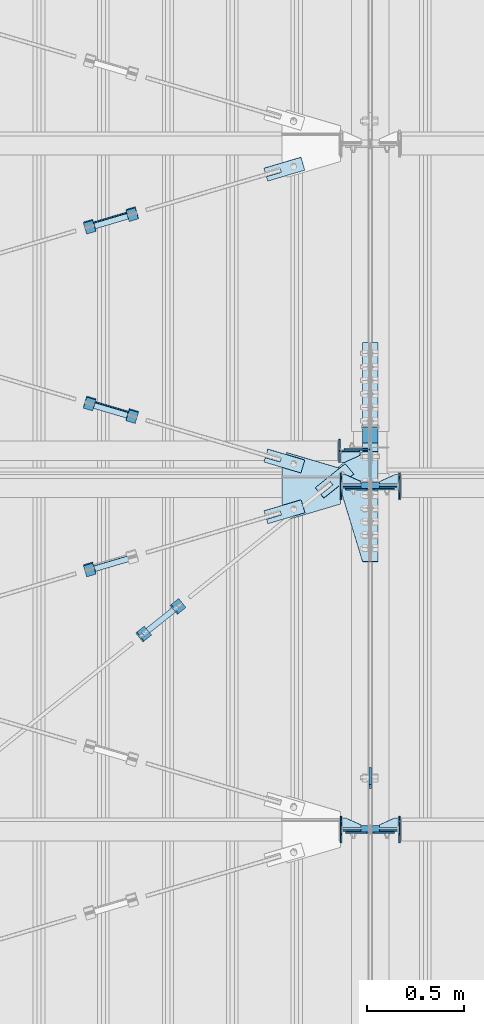
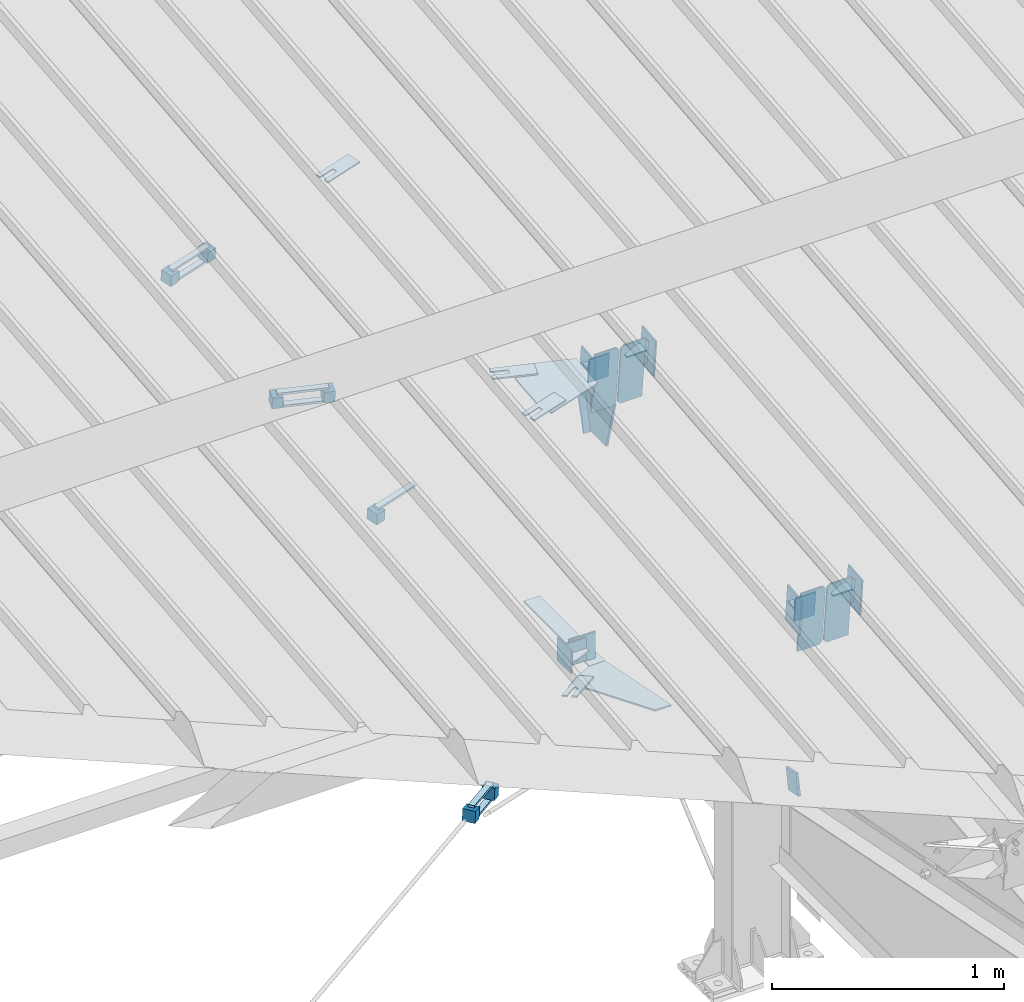
# One storey, part 149 of 709: 44 plates, 3 openings, 16 elements without a shape of their own.
"""IFC4 building model written with IfcOpenShell, lengths in millimetres."""

from ifc_helpers import new_model, si_unit, direction, frame, origin_with_axes, place, context, subcontext, project, spatial, line, indexed_curve, outline, extrude, material, element, aggregate, save


model = new_model("IFC4")

# Units and contexts
model_context = context("Model", 3, precision=0.2, world=origin_with_axes(), true_north=direction((0.0, 1.0)))
body_context = subcontext(model_context, "Body", "Model", "MODEL_VIEW")
ifc_project = project(units=[si_unit("LENGTHUNIT", "METRE", prefix="MILLI"), si_unit("AREAUNIT", "SQUARE_METRE"), si_unit("VOLUMEUNIT", "CUBIC_METRE"), si_unit("MASSUNIT", "GRAM", prefix="KILO"), si_unit("TIMEUNIT", "SECOND"), si_unit("PLANEANGLEUNIT", "RADIAN"), si_unit("SOLIDANGLEUNIT", "STERADIAN"), si_unit("THERMODYNAMICTEMPERATUREUNIT", "DEGREE_CELSIUS"), si_unit("LUMINOUSINTENSITYUNIT", "LUMEN")], contexts=[model_context])

# Site, building, storey
site_placement = place(None, origin_with_axes())
site = spatial("IfcSite", under=ifc_project, at=site_placement, CompositionType="ELEMENT")
building_placement = place(site_placement, origin_with_axes())
building = spatial("IfcBuilding", under=site, at=building_placement, Name="Undefined", CompositionType="ELEMENT")
storey_placement = place(building_placement, origin_with_axes())
storey = spatial("IfcBuildingStorey", under=building, at=storey_placement, Name="Undefined", CompositionType="ELEMENT", Elevation=0.0)

# Assembly, plates
assembly_1_placement = place(storey_placement, frame((46000.0, 346.0, 7089.70002), z_axis=(1.0, 0.0, 0.0), x_axis=(0.0, 0.9950371902, 0.099503719)))
assembly_1 = element("IfcElementAssembly", 1, at=assembly_1_placement, inside=storey)
ifc_material_1 = material(Name="C355-6", Category="STEEL")
plate_1_placement = place(assembly_1_placement, frame((5169.0059, 163.0, 127.0), z_axis=(-1.0, 0.0, 0.0), x_axis=(0.0, 0.0, -1.0)))
plate_1 = element("IfcPlate", 2, at=plate_1_placement, material=ifc_material_1, ObjectType="585", context=body_context, shape_type="SolidModel", body=[
    extrude(outline(indexed_curve([(0.0, 0.0), (108.0, 0.0), (123.0, 15.0), (123.0, 311.0), (108.0, 326.0), (0.0, 326.0)], segments=[line(1, 2, 3, 4, 5, 6, 1)])), frame((0.0, 0.0, 4.0), z_axis=(0.0, 0.0, 1.0), x_axis=(1.0, 0.0, 0.0)), (0.0, 0.0, -1.0), 8.0),
])
plate_2_placement = place(assembly_1_placement, frame((5169.0059, 163.0, -127.0), z_axis=(1.0, 0.0, 0.0), x_axis=(0.0, 0.0, 1.0)))
plate_2 = element("IfcPlate", 3, at=plate_2_placement, material=ifc_material_1, ObjectType="585", context=body_context, shape_type="SolidModel", body=[
    extrude(outline(indexed_curve([(0.0, 0.0), (108.0, 0.0), (123.0, 15.0), (123.0, 311.0), (108.0, 326.0), (0.0, 326.0)], segments=[line(1, 2, 3, 4, 5, 6, 1)])), frame((0.0, 0.0, 4.0), z_axis=(0.0, 0.0, 1.0), x_axis=(1.0, 0.0, 0.0)), (0.0, 0.0, -1.0), 8.0),
])
plate_3_placement = place(assembly_1_placement, frame((3383.44474, 163.0, 127.0), z_axis=(-1.0, 0.0, 0.0), x_axis=(0.0, 0.0, -1.0)))
plate_3 = element("IfcPlate", 4, at=plate_3_placement, material=ifc_material_1, ObjectType="585", context=body_context, shape_type="SolidModel", body=[
    extrude(outline(indexed_curve([(0.0, 0.0), (108.0, 0.0), (123.0, 15.0), (123.0, 311.0), (108.0, 326.0), (0.0, 326.0)], segments=[line(1, 2, 3, 4, 5, 6, 1)])), frame((0.0, 0.0, 4.0), z_axis=(0.0, 0.0, 1.0), x_axis=(1.0, 0.0, 0.0)), (0.0, 0.0, -1.0), 8.0),
])
plate_4_placement = place(assembly_1_placement, frame((3383.44474, 163.0, -127.0), z_axis=(1.0, 0.0, 0.0), x_axis=(0.0, 0.0, 1.0)))
plate_4 = element("IfcPlate", 5, at=plate_4_placement, material=ifc_material_1, ObjectType="585", context=body_context, shape_type="SolidModel", body=[
    extrude(outline(indexed_curve([(0.0, 0.0), (108.0, 0.0), (123.0, 15.0), (123.0, 311.0), (108.0, 326.0), (0.0, 326.0)], segments=[line(1, 2, 3, 4, 5, 6, 1)])), frame((0.0, 0.0, 4.0), z_axis=(0.0, 0.0, 1.0), x_axis=(1.0, 0.0, 0.0)), (0.0, 0.0, -1.0), 8.0),
])
plate_5_placement = place(assembly_1_placement, frame((5458.83099, -172.70172, -40.0), z_axis=(-0.9353786626, 0.3536477874, 0.0), x_axis=(-0.3536477874, -0.9353786626, 0.0)))
plate_5 = element("IfcPlate", 6, at=plate_5_placement, material=ifc_material_1, ObjectType="443", context=body_context, shape_type="SolidModel", body=[
    extrude(outline(indexed_curve([(0.0, 0.0), (298.89845, 0.0), (298.89845, 80.0), (0.0, 80.0)], segments=[line(1, 2, 3, 4, 1)])), frame((0.0, 0.0, 4.0), z_axis=(0.0, 0.0, 1.0), x_axis=(1.0, 0.0, 0.0)), (0.0, 0.0, -1.0), 8.0),
])
plate_6_placement = place(assembly_1_placement, frame((5220.02987, -437.93487, 0.0), z_axis=(0.0, 0.0, -1.0), x_axis=(-0.1614213634, 0.9868855777, 0.0)))
plate_6 = element("IfcPlate", 7, at=plate_6_placement, material=ifc_material_1, ObjectType="442", context=body_context, shape_type="SolidModel", body=[
    extrude(outline(indexed_curve([(0.0, 0.0), (270.19115, 0.0), (225.20717, 275.01958), (-33.64648, 125.57036)], segments=[line(1, 2, 3, 4, 1)])), frame((0.0, 0.0, 6.0), z_axis=(0.0, 0.0, 1.0), x_axis=(1.0, 0.0, 0.0)), (0.0, 0.0, -1.0), 12.0),
])
aggregate(assembly_1, [plate_1, plate_2, plate_3, plate_4, plate_5, plate_6])

# Assembly, plate
assembly_2_placement = place(storey_placement, frame((44916.07962, 4796.2353, 6158.55487), z_axis=(0.625451877, -0.7802627439, 1e-10), x_axis=(0.7742288439, 0.6206151549, -0.124123031)))
assembly_2 = element("IfcElementAssembly", 8, at=assembly_2_placement, inside=storey)
plate_7_placement = place(assembly_2_placement, frame((1061.42526, -5.35577, -34.5878), z_axis=(0.0, -0.9882227647, 0.1530221141), x_axis=(1.0, 0.0, 0.0)))
plate_7 = element("IfcPlate", 9, at=plate_7_placement, material=ifc_material_1, ObjectType="488", context=body_context, shape_type="SolidModel", body=[
    extrude(outline(indexed_curve([(0.0, 0.0), (200.0, 0.0), (200.0, 70.0), (0.0, 70.0), (0.0, 46.0), (80.0, 46.0), (80.0, 24.0), (0.0, 24.0)], segments=[line(1, 2, 3, 4, 5, 6, 7, 8, 1)])), frame((0.0, 0.0, 4.0), z_axis=(0.0, 0.0, 1.0), x_axis=(1.0, 0.0, 0.0)), (0.0, 0.0, -1.0), 8.0),
])
aggregate(assembly_2, [plate_7])

# Assembly, plates
assembly_3_placement = place(storey_placement, frame((45026.78495, 4846.52715, 6174.04872), z_axis=(-0.7742288439, -0.6206151548, 0.1241230313), x_axis=(-0.625451877, 0.780262744, 0.0)))
assembly_3 = element("IfcElementAssembly", 10, at=assembly_3_placement, inside=storey)
ifc_material_2 = material(Name="Steel_Undefined", Category="STEEL")
plate_8_placement = place(assembly_3_placement, frame((15.0, -6.0, 230.0), z_axis=(0.0, 1.0, 0.0), x_axis=(1.0, 0.0, 0.0)))
plate_8 = element("IfcPlate", 11, at=plate_8_placement, material=ifc_material_2, ObjectType="484", context=body_context, shape_type="SolidModel", body=[
    extrude(outline(indexed_curve([(0.0, 0.0), (30.0, 0.0), (30.0, 230.0), (0.0, 230.0)], segments=[line(1, 2, 3, 4, 1)])), frame((0.0, 0.0, 6.0), z_axis=(0.0, 0.0, 1.0), x_axis=(1.0, 0.0, 0.0)), (0.0, 0.0, -1.0), 12.0),
])
plate_9_placement = place(assembly_3_placement, frame((15.0, 66.0, 230.0), z_axis=(0.0, 1.0, 0.0), x_axis=(1.0, 0.0, 0.0)))
plate_9 = element("IfcPlate", 12, at=plate_9_placement, material=ifc_material_2, ObjectType="484", context=body_context, shape_type="SolidModel", body=[
    extrude(outline(indexed_curve([(0.0, 0.0), (30.0, 0.0), (30.0, 230.0), (0.0, 230.0)], segments=[line(1, 2, 3, 4, 1)])), frame((0.0, 0.0, 6.0), z_axis=(0.0, 0.0, 1.0), x_axis=(1.0, 0.0, 0.0)), (0.0, 0.0, -1.0), 12.0),
])
plate_10_placement = place(assembly_3_placement, origin_with_axes())
plate_10 = element("IfcPlate", 13, at=plate_10_placement, material=ifc_material_2, ObjectType="482", context=body_context, shape_type="SolidModel", body=[
    extrude(outline(indexed_curve([(0.0, 0.0), (60.0, 0.0), (60.0, 60.0), (0.0, 60.0)], segments=[line(1, 2, 3, 4, 1)])), frame((0.0, 0.0, 25.0), z_axis=(0.0, 0.0, 1.0), x_axis=(1.0, 0.0, 0.0)), (0.0, 0.0, -1.0), 50.0),
])
plate_11_placement = place(assembly_3_placement, frame((0.0, 0.0, 230.0), z_axis=(0.0, 0.0, 1.0), x_axis=(1.0, 0.0, 0.0)))
plate_11 = element("IfcPlate", 14, at=plate_11_placement, material=ifc_material_2, ObjectType="483", context=body_context, shape_type="SolidModel", body=[
    extrude(outline(indexed_curve([(0.0, 0.0), (60.0, 0.0), (60.0, 60.0), (0.0, 60.0)], segments=[line(1, 2, 3, 4, 1)])), frame((0.0, 0.0, 25.0), z_axis=(0.0, 0.0, 1.0), x_axis=(1.0, 0.0, 0.0)), (0.0, 0.0, -1.0), 50.0),
])
aggregate(assembly_3, [plate_8, plate_9, plate_10, plate_11])

assembly_4_placement = place(storey_placement, frame((46000.0, 5668.61344, 5980.00002), z_axis=(1.0, 0.0, 0.0), x_axis=(0.0, 1.0, 0.0)))
assembly_4 = element("IfcElementAssembly", 15, at=assembly_4_placement, inside=storey)
plate_12_placement = place(assembly_4_placement, frame((-0.78446, -3.92232, 40.0), z_axis=(0.1961161349, 0.9805806757, 0.0), x_axis=(0.0, 0.0, -1.0)))
plate_12 = element("IfcPlate", 16, at=plate_12_placement, material=ifc_material_1, ObjectType="487", context=body_context, shape_type="SolidModel", body=[
    extrude(outline(indexed_curve([(0.0, 0.0), (80.0, 0.0), (175.76932, 57.25102), (253.1922, 120.5416), (196.23068, 190.22219), (80.0, 579.50696), (0.0, 579.50696)], segments=[line(1, 2, 3, 4, 5, 6, 7, 1)])), frame((0.0, 0.0, 4.0), z_axis=(0.0, 0.0, 1.0), x_axis=(1.0, 0.0, 0.0)), (0.0, 0.0, -1.0), 8.0),
])
plate_13_placement = place(assembly_4_placement, frame((564.38656, -4.0, -40.0), z_axis=(0.0, 1.0, 0.0), x_axis=(-1.0, 0.0, 0.0)))
plate_13 = element("IfcPlate", 17, at=plate_13_placement, material=ifc_material_1, ObjectType="446", context=body_context, shape_type="SolidModel", body=[
    extrude(outline(indexed_curve([(0.0, 0.0), (564.38656, 0.0), (564.38656, 80.0), (0.0, 80.0)], segments=[line(1, 2, 3, 4, 1)])), frame((0.0, 0.0, 4.0), z_axis=(0.0, 0.0, 1.0), x_axis=(1.0, 0.0, 0.0)), (0.0, 0.0, -1.0), 8.0),
])
plate_14_placement = place(assembly_4_placement, frame((12.38656, 164.3, -134.0), z_axis=(1.0, 0.0, 0.0), x_axis=(0.0, 0.0, 1.0)))
plate_14 = element("IfcPlate", 18, at=plate_14_placement, material=ifc_material_1, ObjectType="558", context=body_context, shape_type="SolidModel", body=[
    extrude(outline(indexed_curve([(0.0, 0.0), (130.0, 0.0), (130.0, 140.0), (0.0, 140.0)], segments=[line(1, 2, 3, 4, 1)])), frame((0.0, 0.0, 4.0), z_axis=(0.0, 0.0, 1.0), x_axis=(1.0, 0.0, 0.0)), (0.0, 0.0, -1.0), 8.0),
])
aggregate(assembly_4, [plate_12, plate_13, plate_14])

# Assembly, plate
assembly_5_placement = place(storey_placement, frame((46000.0, 3946.08299, 6446.88258), z_axis=(-1.0, 0.0, 0.0), x_axis=(0.0, 0.9805806757, -0.1961161349)))
assembly_5 = element("IfcElementAssembly", 19, at=assembly_5_placement, inside=storey)
plate_15_placement = place(assembly_5_placement, origin_with_axes())
plate_15 = element("IfcPlate", 20, at=plate_15_placement, material=ifc_material_1, ObjectType="491", context=body_context, shape_type="SolidModel", body=[
    extrude(outline(indexed_curve([(0.0, 0.0), (90.0, 0.0), (90.0, 110.0), (0.0, 110.0)], segments=[line(1, 2, 3, 4, 1)])), frame((0.0, 0.0, 6.0), z_axis=(0.0, 0.0, 1.0), x_axis=(1.0, 0.0, 0.0)), (0.0, 0.0, -1.0), 12.0),
])
aggregate(assembly_5, [plate_15])

# Assembly, plates
assembly_6_placement = place(storey_placement, frame((40000.0, 5673.0, 6074.30002), z_axis=(0.0, -1.0, 0.0), x_axis=(1.0, 0.0, 0.0)))
assembly_6 = element("IfcElementAssembly", 21, at=assembly_6_placement, inside=storey)
plate_16_placement = place(assembly_6_placement, frame((5946.0, 60.0, 0.0), z_axis=(0.0, 0.0, -1.0), x_axis=(0.0, -1.0, 0.0)))
plate_16 = element("IfcPlate", 22, at=plate_16_placement, material=ifc_material_1, ObjectType="560", context=body_context, shape_type="SolidModel", body=[
    extrude(outline(indexed_curve([(0.0, 0.0), (120.0, 0.0), (120.0, 100.0), (0.0, 100.0)], segments=[line(1, 2, 3, 4, 1)])), frame((0.0, 0.0, 4.0), z_axis=(0.0, 0.0, 1.0), x_axis=(1.0, 0.0, 0.0)), (0.0, 0.0, -1.0), 8.0),
])
plate_17_placement = place(assembly_6_placement, frame((5842.0, 60.0, -60.0), z_axis=(1.0, 0.0, 0.0), x_axis=(0.0, 0.0, 1.0)))
plate_17 = element("IfcPlate", 23, at=plate_17_placement, material=ifc_material_1, ObjectType="559", context=body_context, shape_type="SolidModel", body=[
    extrude(outline(indexed_curve([(0.0, 0.0), (120.0, 0.0), (120.0, 120.0), (0.0, 120.0)], segments=[line(1, 2, 3, 4, 1)])), frame((0.0, 0.0, 4.0), z_axis=(0.0, 0.0, 1.0), x_axis=(1.0, 0.0, 0.0)), (0.0, 0.0, -1.0), 8.0),
])
plate_18_placement = place(assembly_6_placement, frame((5946.0, 0.0, 60.0), z_axis=(0.0, 1.0, 0.0), x_axis=(0.0, 0.0, -1.0)))
plate_18 = element("IfcPlate", 24, at=plate_18_placement, material=ifc_material_1, ObjectType="561", context=body_context, shape_type="SolidModel", body=[
    extrude(outline(indexed_curve([(0.0, 80.0), (36.0, 0.0), (56.0, 0.0), (56.0, 90.0), (46.0, 100.0), (0.0, 100.0)], segments=[line(1, 2, 3, 4, 5, 6, 1)])), frame((0.0, 0.0, 4.0), z_axis=(0.0, 0.0, 1.0), x_axis=(1.0, 0.0, 0.0)), (0.0, 0.0, -1.0), 8.0),
])
aggregate(assembly_6, [plate_16, plate_17, plate_18])

# Assembly, plate, voiding feature
assembly_7_placement = place(storey_placement, frame((44658.15773, 5091.91179, 7645.6952), z_axis=(0.2852311229, -0.9537021177, -0.0953702118), x_axis=(0.9584587662, 0.2838155751, 0.028381558)))
assembly_7 = element("IfcElementAssembly", 25, at=assembly_7_placement, inside=storey)
plate_19_placement = place(assembly_7_placement, frame((1036.9749, 0.0, 35.0), z_axis=(0.0, 1.0, 0.0), x_axis=(0.0, 0.0, -1.0)))
plate_19 = element("IfcPlate", 26, at=plate_19_placement, material=ifc_material_1, ObjectType="574", context=body_context, shape_type="SolidModel", body=[
    extrude(outline(indexed_curve([(0.0, 0.0), (70.0, 0.0), (70.0, 200.0), (0.0, 200.0)], segments=[line(1, 2, 3, 4, 1)])), frame((0.0, 0.0, 4.0), z_axis=(0.0, 0.0, 1.0), x_axis=(1.0, 0.0, 0.0)), (0.0, 0.0, -1.0), 8.0),
])
voiding_feature_1_placement = place(plate_19_placement, frame((24.0, 120.0, 0.0), z_axis=(0.0, 0.0, 1.0), x_axis=(1.0, 0.0, 0.0)))
element("IfcVoidingFeature", 27, at=voiding_feature_1_placement, cuts=plate_19, Name="PLATE", PredefinedType="HOLE", context=body_context, shape_type="SolidModel", body=[
    extrude(outline(indexed_curve([(0.0, 0.0), (22.0, 0.0), (22.0, 85.0), (0.0, 85.0)], segments=[line(1, 2, 3, 4, 1)])), frame((0.0, 0.0, 6.5), z_axis=(0.0, 0.0, 1.0), x_axis=(1.0, 0.0, 0.0)), (0.0, 0.0, -1.0), 13.0),
])
aggregate(assembly_7, [plate_19])

# Assembly, plates
assembly_8_placement = place(storey_placement, frame((44776.93742, 5092.95441, 7675.94908), z_axis=(-0.9584587662, -0.2838155751, -0.0283815575), x_axis=(-0.2852311229, 0.9537021176, 0.095370212)))
assembly_8 = element("IfcElementAssembly", 28, at=assembly_8_placement, inside=storey)
plate_20_placement = place(assembly_8_placement, frame((0.0, 0.0, 230.0), z_axis=(0.0, 0.0, 1.0), x_axis=(1.0, 0.0, 0.0)))
plate_20 = element("IfcPlate", 29, at=plate_20_placement, material=ifc_material_2, ObjectType="483", context=body_context, shape_type="SolidModel", body=[
    extrude(outline(indexed_curve([(0.0, 0.0), (60.0, 0.0), (60.0, 60.0), (0.0, 60.0)], segments=[line(1, 2, 3, 4, 1)])), frame((0.0, 0.0, 25.0), z_axis=(0.0, 0.0, 1.0), x_axis=(1.0, 0.0, 0.0)), (0.0, 0.0, -1.0), 50.0),
])
plate_21_placement = place(assembly_8_placement, frame((15.0, -6.0, 230.0), z_axis=(0.0, 1.0, 0.0), x_axis=(1.0, 0.0, 0.0)))
plate_21 = element("IfcPlate", 30, at=plate_21_placement, material=ifc_material_2, ObjectType="484", context=body_context, shape_type="SolidModel", body=[
    extrude(outline(indexed_curve([(0.0, 0.0), (30.0, 0.0), (30.0, 230.0), (0.0, 230.0)], segments=[line(1, 2, 3, 4, 1)])), frame((0.0, 0.0, 6.0), z_axis=(0.0, 0.0, 1.0), x_axis=(1.0, 0.0, 0.0)), (0.0, 0.0, -1.0), 12.0),
])
aggregate(assembly_8, [plate_20, plate_21])

# Assembly, plate, voiding feature
assembly_9_placement = place(storey_placement, frame((44657.949, 6865.91062, 7823.09508), z_axis=(0.2847296511, -0.9538504697, -0.095385047), x_axis=(0.9586078582, 0.2833165921, 0.028331659)))
assembly_9 = element("IfcElementAssembly", 31, at=assembly_9_placement, inside=storey)
plate_22_placement = place(assembly_9_placement, frame((1036.31721, 0.0, 35.0), z_axis=(0.0, 1.0, 0.0), x_axis=(0.0, 0.0, -1.0)))
plate_22 = element("IfcPlate", 32, at=plate_22_placement, material=ifc_material_1, ObjectType="574", context=body_context, shape_type="SolidModel", body=[
    extrude(outline(indexed_curve([(0.0, 0.0), (70.0, 0.0), (70.0, 200.0), (0.0, 200.0)], segments=[line(1, 2, 3, 4, 1)])), frame((0.0, 0.0, 4.0), z_axis=(0.0, 0.0, 1.0), x_axis=(1.0, 0.0, 0.0)), (0.0, 0.0, -1.0), 8.0),
])
voiding_feature_2_placement = place(plate_22_placement, frame((24.0, 120.0, 0.0), z_axis=(0.0, 0.0, 1.0), x_axis=(1.0, 0.0, 0.0)))
element("IfcVoidingFeature", 33, at=voiding_feature_2_placement, cuts=plate_22, Name="PLATE", PredefinedType="HOLE", context=body_context, shape_type="SolidModel", body=[
    extrude(outline(indexed_curve([(0.0, 0.0), (22.0, 0.0), (22.0, 85.0), (0.0, 85.0)], segments=[line(1, 2, 3, 4, 1)])), frame((0.0, 0.0, 6.5), z_axis=(0.0, 0.0, 1.0), x_axis=(1.0, 0.0, 0.0)), (0.0, 0.0, -1.0), 13.0),
])
aggregate(assembly_9, [plate_22])

# Assembly, plates
assembly_10_placement = place(storey_placement, frame((44776.73079, 6866.8914, 7853.34278), z_axis=(-0.9586078582, -0.2833165918, -0.0283316592), x_axis=(-0.2847296509, 0.9538504698, 0.095385047)))
assembly_10 = element("IfcElementAssembly", 34, at=assembly_10_placement, inside=storey)
plate_23_placement = place(assembly_10_placement, origin_with_axes())
plate_23 = element("IfcPlate", 35, at=plate_23_placement, material=ifc_material_2, ObjectType="482", context=body_context, shape_type="SolidModel", body=[
    extrude(outline(indexed_curve([(0.0, 0.0), (60.0, 0.0), (60.0, 60.0), (0.0, 60.0)], segments=[line(1, 2, 3, 4, 1)])), frame((0.0, 0.0, 25.0), z_axis=(0.0, 0.0, 1.0), x_axis=(1.0, 0.0, 0.0)), (0.0, 0.0, -1.0), 50.0),
])
plate_24_placement = place(assembly_10_placement, frame((0.0, 0.0, 230.0), z_axis=(0.0, 0.0, 1.0), x_axis=(1.0, 0.0, 0.0)))
plate_24 = element("IfcPlate", 36, at=plate_24_placement, material=ifc_material_2, ObjectType="483", context=body_context, shape_type="SolidModel", body=[
    extrude(outline(indexed_curve([(0.0, 0.0), (60.0, 0.0), (60.0, 60.0), (0.0, 60.0)], segments=[line(1, 2, 3, 4, 1)])), frame((0.0, 0.0, 25.0), z_axis=(0.0, 0.0, 1.0), x_axis=(1.0, 0.0, 0.0)), (0.0, 0.0, -1.0), 50.0),
])
plate_25_placement = place(assembly_10_placement, frame((15.0, -6.0, 230.0), z_axis=(0.0, 1.0, 0.0), x_axis=(1.0, 0.0, 0.0)))
plate_25 = element("IfcPlate", 37, at=plate_25_placement, material=ifc_material_2, ObjectType="484", context=body_context, shape_type="SolidModel", body=[
    extrude(outline(indexed_curve([(0.0, 0.0), (30.0, 0.0), (30.0, 230.0), (0.0, 230.0)], segments=[line(1, 2, 3, 4, 1)])), frame((0.0, 0.0, 6.0), z_axis=(0.0, 0.0, 1.0), x_axis=(1.0, 0.0, 0.0)), (0.0, 0.0, -1.0), 12.0),
])
plate_26_placement = place(assembly_10_placement, frame((15.0, 66.0, 230.0), z_axis=(0.0, 1.0, 0.0), x_axis=(1.0, 0.0, 0.0)))
plate_26 = element("IfcPlate", 38, at=plate_26_placement, material=ifc_material_2, ObjectType="484", context=body_context, shape_type="SolidModel", body=[
    extrude(outline(indexed_curve([(0.0, 0.0), (30.0, 0.0), (30.0, 230.0), (0.0, 230.0)], segments=[line(1, 2, 3, 4, 1)])), frame((0.0, 0.0, 6.0), z_axis=(0.0, 0.0, 1.0), x_axis=(1.0, 0.0, 0.0)), (0.0, 0.0, -1.0), 12.0),
])
aggregate(assembly_10, [plate_23, plate_24, plate_25, plate_26])

# Assembly, plate, voiding feature
assembly_11_placement = place(storey_placement, frame((44657.949, 5885.89683, 7725.0937), z_axis=(-0.2847296511, -0.9538504697, -0.095385047), x_axis=(0.9586078582, -0.2833165921, -0.028331659)))
assembly_11 = element("IfcElementAssembly", 39, at=assembly_11_placement, inside=storey)
plate_27_placement = place(assembly_11_placement, frame((1036.31721, 0.0, 35.0), z_axis=(0.0, 1.0, 0.0), x_axis=(0.0, 0.0, -1.0)))
plate_27 = element("IfcPlate", 40, at=plate_27_placement, material=ifc_material_1, ObjectType="574", context=body_context, shape_type="SolidModel", body=[
    extrude(outline(indexed_curve([(0.0, 0.0), (70.0, 0.0), (70.0, 200.0), (0.0, 200.0)], segments=[line(1, 2, 3, 4, 1)])), frame((0.0, 0.0, 4.0), z_axis=(0.0, 0.0, 1.0), x_axis=(1.0, 0.0, 0.0)), (0.0, 0.0, -1.0), 8.0),
])
voiding_feature_3_placement = place(plate_27_placement, frame((24.0, 120.0, 0.0), z_axis=(0.0, 0.0, 1.0), x_axis=(1.0, 0.0, 0.0)))
element("IfcVoidingFeature", 41, at=voiding_feature_3_placement, cuts=plate_27, Name="PLATE", PredefinedType="HOLE", context=body_context, shape_type="SolidModel", body=[
    extrude(outline(indexed_curve([(0.0, 0.0), (22.0, 0.0), (22.0, 85.0), (0.0, 85.0)], segments=[line(1, 2, 3, 4, 1)])), frame((0.0, 0.0, 6.5), z_axis=(0.0, 0.0, 1.0), x_axis=(1.0, 0.0, 0.0)), (0.0, 0.0, -1.0), 13.0),
])
aggregate(assembly_11, [plate_27])

# Assembly, plates
assembly_12_placement = place(storey_placement, frame((44759.64701, 5821.71479, 7748.82512), z_axis=(-0.9586078582, 0.2833165918, 0.0283316592), x_axis=(0.2847296509, 0.9538504698, 0.095385047)))
assembly_12 = element("IfcElementAssembly", 42, at=assembly_12_placement, inside=storey)
plate_28_placement = place(assembly_12_placement, frame((0.0, 0.0, 230.0), z_axis=(0.0, 0.0, 1.0), x_axis=(1.0, 0.0, 0.0)))
plate_28 = element("IfcPlate", 43, at=plate_28_placement, material=ifc_material_2, ObjectType="483", context=body_context, shape_type="SolidModel", body=[
    extrude(outline(indexed_curve([(0.0, 0.0), (60.0, 0.0), (60.0, 60.0), (0.0, 60.0)], segments=[line(1, 2, 3, 4, 1)])), frame((0.0, 0.0, 25.0), z_axis=(0.0, 0.0, 1.0), x_axis=(1.0, 0.0, 0.0)), (0.0, 0.0, -1.0), 50.0),
])
plate_29_placement = place(assembly_12_placement, origin_with_axes())
plate_29 = element("IfcPlate", 44, at=plate_29_placement, material=ifc_material_2, ObjectType="482", context=body_context, shape_type="SolidModel", body=[
    extrude(outline(indexed_curve([(0.0, 0.0), (60.0, 0.0), (60.0, 60.0), (0.0, 60.0)], segments=[line(1, 2, 3, 4, 1)])), frame((0.0, 0.0, 25.0), z_axis=(0.0, 0.0, 1.0), x_axis=(1.0, 0.0, 0.0)), (0.0, 0.0, -1.0), 50.0),
])
plate_30_placement = place(assembly_12_placement, frame((15.0, 66.0, 230.0), z_axis=(0.0, 1.0, 0.0), x_axis=(1.0, 0.0, 0.0)))
plate_30 = element("IfcPlate", 45, at=plate_30_placement, material=ifc_material_2, ObjectType="484", context=body_context, shape_type="SolidModel", body=[
    extrude(outline(indexed_curve([(0.0, 0.0), (30.0, 0.0), (30.0, 230.0), (0.0, 230.0)], segments=[line(1, 2, 3, 4, 1)])), frame((0.0, 0.0, 6.0), z_axis=(0.0, 0.0, 1.0), x_axis=(1.0, 0.0, 0.0)), (0.0, 0.0, -1.0), 12.0),
])
plate_31_placement = place(assembly_12_placement, frame((15.0, -6.0, 230.0), z_axis=(0.0, 1.0, 0.0), x_axis=(1.0, 0.0, 0.0)))
plate_31 = element("IfcPlate", 46, at=plate_31_placement, material=ifc_material_2, ObjectType="484", context=body_context, shape_type="SolidModel", body=[
    extrude(outline(indexed_curve([(0.0, 0.0), (30.0, 0.0), (30.0, 230.0), (0.0, 230.0)], segments=[line(1, 2, 3, 4, 1)])), frame((0.0, 0.0, 6.0), z_axis=(0.0, 0.0, 1.0), x_axis=(1.0, 0.0, 0.0)), (0.0, 0.0, -1.0), 12.0),
])
aggregate(assembly_12, [plate_28, plate_29, plate_30, plate_31])

assembly_13_placement = place(storey_placement, frame((40000.0, 3713.34988, 7499.7991), z_axis=(0.0, 0.9950371902, 0.099503719), x_axis=(1.0, 0.0, 0.0)))
assembly_13 = element("IfcElementAssembly", 47, at=assembly_13_placement, inside=storey)
plate_32_placement = place(assembly_13_placement, frame((5953.0, 0.0, 60.0), z_axis=(0.0, -1.0, 0.0), x_axis=(-1.0, 0.0, 0.0)))
plate_32 = element("IfcPlate", 48, at=plate_32_placement, material=ifc_material_1, ObjectType="588", context=body_context, shape_type="SolidModel", body=[
    extrude(outline(indexed_curve([(0.0, 36.0), (80.0, 0.0), (100.0, 0.0), (100.0, 56.0), (0.0, 56.0)], segments=[line(1, 2, 3, 4, 5, 1)])), frame((0.0, 0.0, 4.0), z_axis=(0.0, 0.0, 1.0), x_axis=(1.0, 0.0, 0.0)), (0.0, 0.0, -1.0), 8.0),
])
plate_33_placement = place(assembly_13_placement, frame((5953.0, 65.0, 0.0), z_axis=(0.0, 0.0, 1.0), x_axis=(-1.0, 0.0, 0.0)))
plate_33 = element("IfcPlate", 49, at=plate_33_placement, material=ifc_material_1, ObjectType="587", context=body_context, shape_type="SolidModel", body=[
    extrude(outline(indexed_curve([(0.0, 0.0), (100.0, 0.0), (100.0, 130.0), (0.0, 130.0)], segments=[line(1, 2, 3, 4, 1)])), frame((0.0, 0.0, 4.0), z_axis=(0.0, 0.0, 1.0), x_axis=(1.0, 0.0, 0.0)), (0.0, 0.0, -1.0), 8.0),
])
plate_34_placement = place(assembly_13_placement, frame((5849.0, -98.0, 60.0), z_axis=(1.0, 0.0, 0.0), x_axis=(0.0, 0.0, -1.0)))
plate_34 = element("IfcPlate", 50, at=plate_34_placement, material=ifc_material_1, ObjectType="586", context=body_context, shape_type="SolidModel", body=[
    extrude(outline(indexed_curve([(0.0, 0.0), (120.0, 0.0), (120.0, 196.0), (0.0, 196.0)], segments=[line(1, 2, 3, 4, 1)])), frame((0.0, 0.0, 4.0), z_axis=(0.0, 0.0, 1.0), x_axis=(1.0, 0.0, 0.0)), (0.0, 0.0, -1.0), 8.0),
])
aggregate(assembly_13, [plate_32, plate_33, plate_34])

assembly_14_placement = place(storey_placement, frame((46000.0, 3713.34988, 7499.7991), z_axis=(0.0, 0.9950371902, 0.099503719), x_axis=(1.0, 0.0, 0.0)))
assembly_14 = element("IfcElementAssembly", 51, at=assembly_14_placement, inside=storey)
plate_35_placement = place(assembly_14_placement, frame((47.0, 0.0, 60.0), z_axis=(0.0, 1.0, 0.0), x_axis=(1.0, 0.0, 0.0)))
plate_35 = element("IfcPlate", 52, at=plate_35_placement, material=ifc_material_1, ObjectType="588", context=body_context, shape_type="SolidModel", body=[
    extrude(outline(indexed_curve([(0.0, 36.0), (80.0, 0.0), (100.0, 0.0), (100.0, 56.0), (0.0, 56.0)], segments=[line(1, 2, 3, 4, 5, 1)])), frame((0.0, 0.0, 4.0), z_axis=(0.0, 0.0, 1.0), x_axis=(1.0, 0.0, 0.0)), (0.0, 0.0, -1.0), 8.0),
])
plate_36_placement = place(assembly_14_placement, frame((47.0, -65.0, 0.0), z_axis=(0.0, 0.0, 1.0), x_axis=(1.0, 0.0, 0.0)))
plate_36 = element("IfcPlate", 53, at=plate_36_placement, material=ifc_material_1, ObjectType="587", context=body_context, shape_type="SolidModel", body=[
    extrude(outline(indexed_curve([(0.0, 0.0), (100.0, 0.0), (100.0, 130.0), (0.0, 130.0)], segments=[line(1, 2, 3, 4, 1)])), frame((0.0, 0.0, 4.0), z_axis=(0.0, 0.0, 1.0), x_axis=(1.0, 0.0, 0.0)), (0.0, 0.0, -1.0), 8.0),
])
plate_37_placement = place(assembly_14_placement, frame((151.0, -98.0, -60.0), z_axis=(-1.0, 0.0, 0.0), x_axis=(0.0, 0.0, 1.0)))
plate_37 = element("IfcPlate", 54, at=plate_37_placement, material=ifc_material_1, ObjectType="586", context=body_context, shape_type="SolidModel", body=[
    extrude(outline(indexed_curve([(0.0, 0.0), (120.0, 0.0), (120.0, 196.0), (0.0, 196.0)], segments=[line(1, 2, 3, 4, 1)])), frame((0.0, 0.0, 4.0), z_axis=(0.0, 0.0, 1.0), x_axis=(1.0, 0.0, 0.0)), (0.0, 0.0, -1.0), 8.0),
])
aggregate(assembly_14, [plate_35, plate_36, plate_37])

assembly_15_placement = place(storey_placement, frame((40000.0, 5490.04963, 7677.46908), z_axis=(0.0, 0.9950371902, 0.099503719), x_axis=(1.0, 0.0, 0.0)))
assembly_15 = element("IfcElementAssembly", 55, at=assembly_15_placement, inside=storey)
plate_38_placement = place(assembly_15_placement, frame((5953.0, 0.0, 60.0), z_axis=(0.0, -1.0, 0.0), x_axis=(-1.0, 0.0, 0.0)))
plate_38 = element("IfcPlate", 56, at=plate_38_placement, material=ifc_material_1, ObjectType="588", context=body_context, shape_type="SolidModel", body=[
    extrude(outline(indexed_curve([(0.0, 36.0), (80.0, 0.0), (100.0, 0.0), (100.0, 56.0), (0.0, 56.0)], segments=[line(1, 2, 3, 4, 5, 1)])), frame((0.0, 0.0, 4.0), z_axis=(0.0, 0.0, 1.0), x_axis=(1.0, 0.0, 0.0)), (0.0, 0.0, -1.0), 8.0),
])
plate_39_placement = place(assembly_15_placement, frame((5953.0, 65.0, 0.0), z_axis=(0.0, 0.0, 1.0), x_axis=(-1.0, 0.0, 0.0)))
plate_39 = element("IfcPlate", 57, at=plate_39_placement, material=ifc_material_1, ObjectType="587", context=body_context, shape_type="SolidModel", body=[
    extrude(outline(indexed_curve([(0.0, 0.0), (100.0, 0.0), (100.0, 130.0), (0.0, 130.0)], segments=[line(1, 2, 3, 4, 1)])), frame((0.0, 0.0, 4.0), z_axis=(0.0, 0.0, 1.0), x_axis=(1.0, 0.0, 0.0)), (0.0, 0.0, -1.0), 8.0),
])
plate_40_placement = place(assembly_15_placement, frame((5849.0, -98.0, 60.0), z_axis=(1.0, 0.0, 0.0), x_axis=(0.0, 0.0, -1.0)))
plate_40 = element("IfcPlate", 58, at=plate_40_placement, material=ifc_material_1, ObjectType="586", context=body_context, shape_type="SolidModel", body=[
    extrude(outline(indexed_curve([(0.0, 0.0), (120.0, 0.0), (120.0, 196.0), (0.0, 196.0)], segments=[line(1, 2, 3, 4, 1)])), frame((0.0, 0.0, 4.0), z_axis=(0.0, 0.0, 1.0), x_axis=(1.0, 0.0, 0.0)), (0.0, 0.0, -1.0), 8.0),
])
plate_41_placement = place(assembly_15_placement, frame((5845.00055, 0.0, -93.07721), z_axis=(0.0, -1.0, 0.0), x_axis=(0.0, 0.0, 1.0)))
plate_41 = element("IfcPlate", 59, at=plate_41_placement, material=ifc_material_1, ObjectType="576", context=body_context, shape_type="SolidModel", body=[
    extrude(outline(indexed_curve([(0.0, 0.0), (186.05886, 0.0), (268.2388, 276.67769), (181.9641, 302.30336), (4.13868, 301.62642), (-82.1226, 275.95562)], segments=[line(1, 2, 3, 4, 5, 6, 1)])), frame((0.0, 0.0, 4.0), z_axis=(0.0, 0.0, 1.0), x_axis=(1.0, 0.0, 0.0)), (0.0, 0.0, -1.0), 8.0),
])
aggregate(assembly_15, [plate_38, plate_39, plate_40, plate_41])

assembly_16_placement = place(storey_placement, frame((46000.0, 5490.04963, 7677.46908), z_axis=(0.0, 0.9950371902, 0.099503719), x_axis=(1.0, 0.0, 0.0)))
assembly_16 = element("IfcElementAssembly", 60, at=assembly_16_placement, inside=storey)
plate_42_placement = place(assembly_16_placement, frame((47.0, 0.0, 60.0), z_axis=(0.0, 1.0, 0.0), x_axis=(1.0, 0.0, 0.0)))
plate_42 = element("IfcPlate", 61, at=plate_42_placement, material=ifc_material_1, ObjectType="588", context=body_context, shape_type="SolidModel", body=[
    extrude(outline(indexed_curve([(0.0, 36.0), (80.0, 0.0), (100.0, 0.0), (100.0, 56.0), (0.0, 56.0)], segments=[line(1, 2, 3, 4, 5, 1)])), frame((0.0, 0.0, 4.0), z_axis=(0.0, 0.0, 1.0), x_axis=(1.0, 0.0, 0.0)), (0.0, 0.0, -1.0), 8.0),
])
plate_43_placement = place(assembly_16_placement, frame((151.0, -98.0, -60.0), z_axis=(-1.0, 0.0, 0.0), x_axis=(0.0, 0.0, 1.0)))
plate_43 = element("IfcPlate", 62, at=plate_43_placement, material=ifc_material_1, ObjectType="586", context=body_context, shape_type="SolidModel", body=[
    extrude(outline(indexed_curve([(0.0, 0.0), (120.0, 0.0), (120.0, 196.0), (0.0, 196.0)], segments=[line(1, 2, 3, 4, 1)])), frame((0.0, 0.0, 4.0), z_axis=(0.0, 0.0, 1.0), x_axis=(1.0, 0.0, 0.0)), (0.0, 0.0, -1.0), 8.0),
])
plate_44_placement = place(assembly_16_placement, frame((47.0, -65.0, 0.0), z_axis=(0.0, 0.0, 1.0), x_axis=(1.0, 0.0, 0.0)))
plate_44 = element("IfcPlate", 63, at=plate_44_placement, material=ifc_material_1, ObjectType="587", context=body_context, shape_type="SolidModel", body=[
    extrude(outline(indexed_curve([(0.0, 0.0), (100.0, 0.0), (100.0, 130.0), (0.0, 130.0)], segments=[line(1, 2, 3, 4, 1)])), frame((0.0, 0.0, 4.0), z_axis=(0.0, 0.0, 1.0), x_axis=(1.0, 0.0, 0.0)), (0.0, 0.0, -1.0), 8.0),
])
aggregate(assembly_16, [plate_42, plate_43, plate_44])

save(model, "model.ifc")
